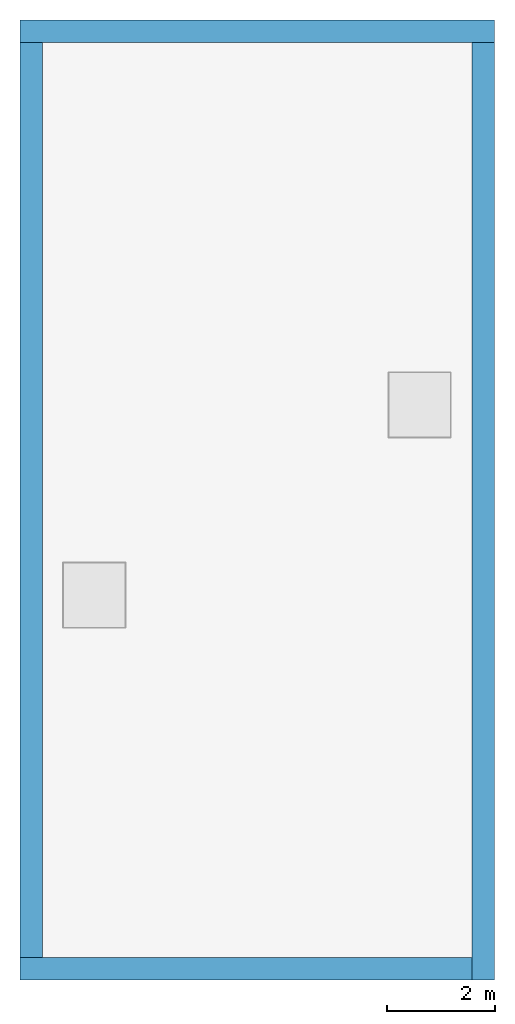
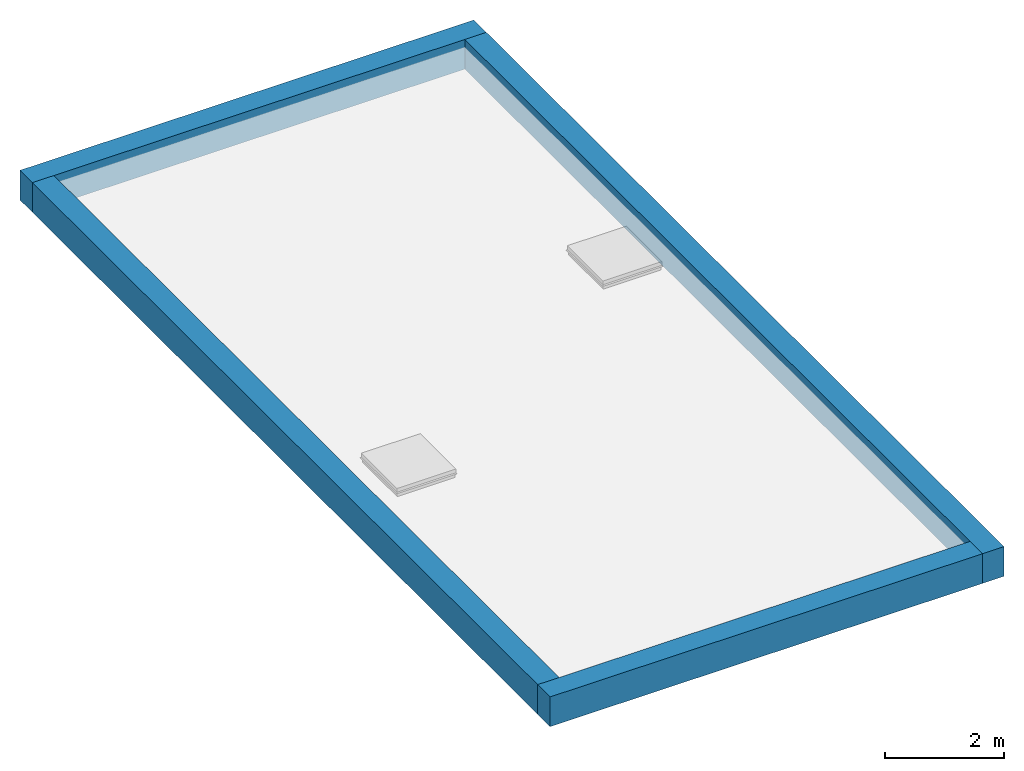
# One storey, part 1 of 2: 4 walls.
"""IFC2X3 building model written with IfcOpenShell, lengths in metres."""

from ifc_helpers import new_model, entity, si_unit, converted_unit, frame, frame_2d, origin, place, context, project, spatial, rectangle, extrude, material, layer, layer_set, layer_usage, element, save


model = new_model("IFC2X3")

# Units and contexts
model_context = context("Model", 3, precision=1e-09, world=origin())
plan_context = context("Plan", 3, precision=1e-09, world=origin())
ifc_project = project(units=[si_unit("LENGTHUNIT", "METRE"), si_unit("AREAUNIT", "SQUARE_METRE"), si_unit("VOLUMEUNIT", "CUBIC_METRE"), converted_unit("PLANEANGLEUNIT", "DEGREE", entity("IfcRatioMeasure", 0.01745329251994328), si_unit("PLANEANGLEUNIT", "RADIAN"), dimensions=[0, 0, 0, 0, 0, 0, 0]), si_unit("TIMEUNIT", "SECOND")], contexts=[model_context, plan_context])

# Site, building, storey
site_placement = place(None, origin())
site = spatial("IfcSite", under=ifc_project, at=site_placement, CompositionType="ELEMENT")
building_placement = place(site_placement, origin())
building = spatial("IfcBuilding", under=site, at=building_placement, CompositionType="ELEMENT")
storey_placement = place(building_placement, frame((0.0, 0.0, 6.0)))
storey = spatial("IfcBuildingStorey", under=building, at=storey_placement, Name="Roof", CompositionType="ELEMENT", Elevation=6.00000000000039)

# Walls
ifc_material_1 = material(Name="Masonry - Brick")
ifc_layer_1 = layer(ifc_material_1, 0.092)
ifc_material_2 = material(Name="Misc. Air Layers - Air Space")
ifc_layer_2 = layer(ifc_material_2, 0.025)
ifc_material_3 = material(Name="Insulation / Thermal Barriers - Rigid insulation")
ifc_layer_3 = layer(ifc_material_3, 0.05)
ifc_material_4 = material(Name="Masonry - Concrete Block")
ifc_layer_4 = layer(ifc_material_4, 0.193)
ifc_material_5 = material(Name="Metal - Stud Layer")
ifc_layer_5 = layer(ifc_material_5, 0.041)
ifc_material_6 = material(Name="Plasterboard")
ifc_layer_6 = layer(ifc_material_6, 0.016)
ifc_layer_set = layer_set([ifc_layer_1, ifc_layer_2, ifc_layer_3, ifc_layer_4, ifc_layer_5, ifc_layer_6], Name="Basic Wall:Exterior - Brick on Block")
ifc_layer_usage = layer_usage(ifc_layer_set, "AXIS2", "NEGATIVE", 0.2085000000000001)
wall_1_placement = place(storey_placement, frame((8.5915, -0.4170000000000275, 0.0), z_axis=(0.0, 0.0, 1.0), x_axis=(0.0, -1.0, 0.0)))
element("IfcWallStandardCase", 1, at=wall_1_placement, inside=storey, material=ifc_layer_usage, Name="Basic Wall:Exterior - Brick on Block", ObjectType="Basic Wall:Exterior - Brick on Block", context=model_context, shape_type="SweptSolid", body=[
    extrude(rectangle(XDim=17.38299999999997, YDim=0.4170000000000005, at=frame_2d((8.691499999999987, 0.0), x_axis=(-1.0, 0.0))), origin(), (0.0, 0.0, 1.0), 0.6090000000000002),
])
wall_2_placement = place(storey_placement, frame((0.0, -0.2085000000000001, 0.0)))
element("IfcWallStandardCase", 2, at=wall_2_placement, inside=storey, material=ifc_layer_usage, Name="Basic Wall:Exterior - Brick on Block", ObjectType="Basic Wall:Exterior - Brick on Block", context=model_context, shape_type="SweptSolid", body=[
    extrude(rectangle(XDim=8.800000000000002, YDim=0.4170000000000001, at=frame_2d((4.400000000000001, 0.0), x_axis=(-1.0, 0.0))), origin(), (0.0, 0.0, 1.0), 0.6090000000000002),
])
wall_3_placement = place(storey_placement, frame((8.382999999999972, -17.5915, 0.0), z_axis=(0.0, 0.0, 1.0), x_axis=(-1.0, 0.0, 0.0)))
element("IfcWallStandardCase", 3, at=wall_3_placement, inside=storey, material=ifc_layer_usage, Name="Basic Wall:Exterior - Brick on Block", ObjectType="Basic Wall:Exterior - Brick on Block", context=model_context, shape_type="SweptSolid", body=[
    extrude(rectangle(XDim=8.382999999999974, YDim=0.4170000000000005, at=frame_2d((4.191499999999987, 0.0), x_axis=(-1.0, 0.0))), origin(), (0.0, 0.0, 1.0), 0.6090000000000002),
])
wall_4_placement = place(storey_placement, frame((0.208499999999999, -17.38299999999997, 0.0), z_axis=(0.0, 0.0, 1.0), x_axis=(0.0, 1.0, 0.0)))
element("IfcWallStandardCase", 4, at=wall_4_placement, inside=storey, material=ifc_layer_usage, Name="Basic Wall:Exterior - Brick on Block", ObjectType="Basic Wall:Exterior - Brick on Block", context=model_context, shape_type="SweptSolid", body=[
    extrude(rectangle(XDim=16.96599999999997, YDim=0.4170000000000001, at=frame_2d((8.482999999999986, 0.0), x_axis=(-1.0, 0.0))), origin(), (0.0, 0.0, 1.0), 0.6090000000000002),
])

save(model, "model.ifc")
